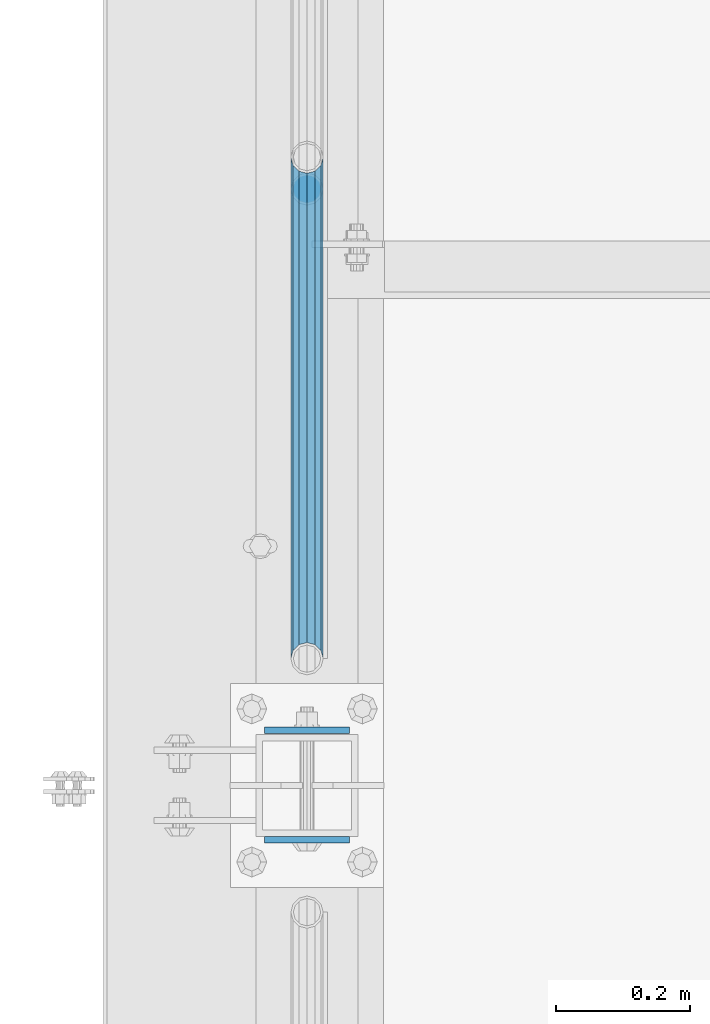
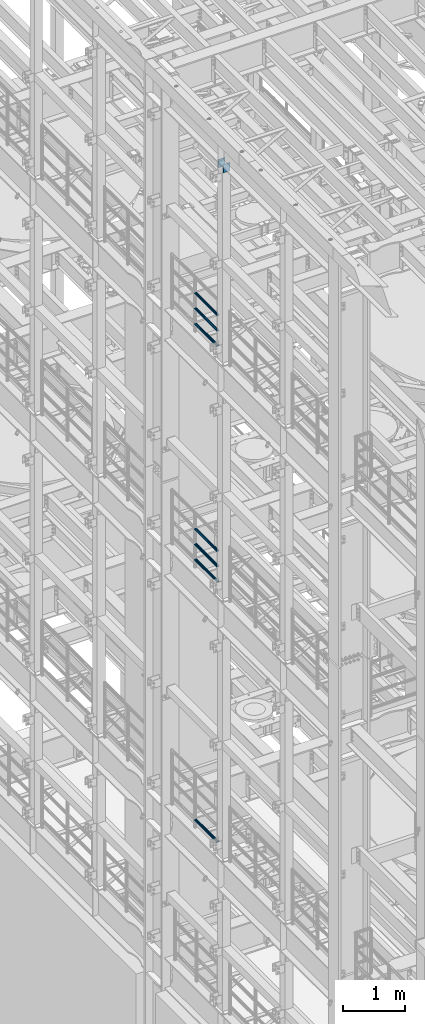
# One storey, part 1230 of 1876: 9 beams, 4 elements without a shape of their own.
"""IFC2X3 building model written with IfcOpenShell, lengths in millimetres."""

from ifc_helpers import new_model, si_unit, frame, origin_with_axes, place, context, subcontext, project, spatial, faceted_brep, material, type_object, element, aggregate, save


model = new_model("IFC2X3")

# Units and contexts
model_context = context("Model", 3, precision=1e-05, world=origin_with_axes())
body_context = subcontext(model_context, "Body", "Model", "MODEL_VIEW")
ifc_project = project(units=[si_unit("LENGTHUNIT", "METRE", prefix="MILLI"), si_unit("AREAUNIT", "SQUARE_METRE"), si_unit("VOLUMEUNIT", "CUBIC_METRE"), si_unit("MASSUNIT", "GRAM", prefix="KILO"), si_unit("TIMEUNIT", "SECOND"), si_unit("PLANEANGLEUNIT", "RADIAN"), si_unit("SOLIDANGLEUNIT", "STERADIAN"), si_unit("THERMODYNAMICTEMPERATUREUNIT", "DEGREE_CELSIUS"), si_unit("LUMINOUSINTENSITYUNIT", "LUMEN")], contexts=[model_context])

# Site, building, storey
site_placement = place(None, origin_with_axes())
site = spatial("IfcSite", under=ifc_project, at=site_placement, CompositionType="ELEMENT")
building_placement = place(site_placement, origin_with_axes())
building = spatial("IfcBuilding", under=site, at=building_placement, Name="Undefined", CompositionType="ELEMENT")
storey_placement = place(building_placement, origin_with_axes())
storey = spatial("IfcBuildingStorey", under=building, at=storey_placement, Name="Undefined", CompositionType="ELEMENT", Elevation=0.0)

# Assembly, beams
assembly_1_placement = place(storey_placement, origin_with_axes())
assembly_1 = element("IfcElementAssembly", 1, at=assembly_1_placement, inside=storey, Name="RAIL", AssemblyPlace="NOTDEFINED", PredefinedType="RIGID_FRAME")
ifc_material_1 = material()
beam_type_1 = type_object("IfcBeamType", Name="PIPE1-1/2SCH40", PredefinedType="NOTDEFINED")
beam_1_placement = place(assembly_1_placement, frame((-1.81898940354586e-12, 430.212499999999, 18145.125), z_axis=(0.0, 0.0, 1.0), x_axis=(0.0, -1.0, 0.0)))
beam_1 = element("IfcBeam", 2, at=beam_1_placement, type_object=beam_type_1, material=ifc_material_1, Name="RAIL", ObjectType="PIPE1-1/2SCH40", context=body_context, shape_type="Brep", body=[
    faceted_brep([(728.085307006683, -12.0649999999996, 20.8971929933177), (728.085307006683, -12.0649999999996, 15.8661214311796), (727.591878568821, -10.2235000000001, 17.7076214311819), (724.852500000002, 0.0, 20.4470000000001), (724.852500000002, 0.0, 24.130000000001), (727.591878568821, 10.2235000000001, 17.7076214311819), (728.085307006683, 12.0649999999996, 15.8661214311796), (728.085307006683, 12.0649999999996, 20.8971929933177), (748.982500000002, 24.1300000000001, 0.0), (736.917500000002, 20.8971929933186, 12.0649999999987), (736.917500000002, 20.8971929933186, -12.0649999999987), (733.727928437864, 17.7076214311801, 10.2235000000001), (736.467307006683, 20.4470000000001, 0.0), (733.727928437864, 17.7076214311801, -10.2235000000001), (728.085307006683, 12.0649999999996, -15.8661214311796), (728.085307006683, 12.0649999999996, -20.8971929933177), (727.591878568821, 10.2235000000001, -17.7076214311819), (724.852500000002, 0.0, -20.4470000000001), (724.852500000002, 0.0, -24.130000000001), (728.085307006683, -12.0649999999996, -15.8661214311796), (728.085307006683, -12.0649999999996, -20.8971929933177), (727.591878568821, -10.2235000000001, -17.7076214311819), (748.982500000002, -24.1300000000001, 0.0), (736.917500000002, -20.8971929933186, -12.0649999999987), (736.917500000002, -20.8971929933186, 12.0649999999987), (733.727928437864, -17.7076214311801, -10.2235000000001), (736.467307006683, -20.4470000000001, 0.0), (733.727928437864, -17.7076214311801, 10.2235000000001), (12.0650000000064, -20.8971929933177, -12.0649999999987), (20.8971929933249, -12.0650000000005, -20.8971929933177), (0.0, 24.1299999999992, 0.0), (12.0650000000064, 20.8971929933177, -12.0649999999987), (12.0650000000064, 20.8971929933177, 12.0649999999987), (20.8971929933249, 12.0650000000005, 20.8971929933177), (24.1300000000064, 0.0, 24.130000000001), (20.8971929933249, 12.0650000000005, -20.8971929933177), (24.1300000000063, 0.0, -24.130000000001), (24.1300000000063, 0.0, -20.4470000000001), (20.8971929933249, -12.0650000000005, -15.8661214311796), (21.3906214311868, -10.2235000000001, -17.7076214311819), (21.3906214311868, 10.2235000000001, -17.7076214311819), (20.8971929933249, 12.0650000000005, -15.8661214311796), (15.2545715621445, 17.7076214311801, -10.2235000000001), (12.5151929933249, 20.4470000000001, 0.0), (15.2545715621445, 17.7076214311801, 10.2235000000001), (20.8971929933249, 12.0650000000005, 15.8661214311796), (21.3906214311868, 10.2235000000001, 17.7076214311819), (24.1300000000064, 0.0, 20.4470000000001), (21.3906214311868, -10.2235000000001, 17.7076214311819), (20.8971929933249, -12.0650000000005, 15.8661214311796), (20.8971929933249, -12.0650000000005, 20.8971929933177), (12.0650000000064, -20.8971929933177, 12.0649999999987), (0.0, -24.1299999999992, 0.0), (15.2545715621445, -17.7076214311801, 10.2235000000001), (12.5151929933249, -20.4470000000001, 0.0), (15.2545715621445, -17.7076214311801, -10.2235000000001)], [[[0, 1, 2, 3, 4]], [[4, 3, 5, 6, 7]], [[8, 9, 10]], [[7, 6, 11, 12, 13, 14, 15, 10, 9]], [[16, 17, 18, 15, 14]], [[19, 20, 18, 17, 21]], [[22, 23, 24]], [[24, 23, 20, 19, 25, 26, 27, 1, 0]], [[28, 29, 20, 23]], [[30, 31, 32]], [[33, 34, 4, 7]], [[32, 33, 7, 9]], [[30, 32, 9, 8]], [[31, 30, 8, 10]], [[35, 31, 10, 15]], [[36, 35, 15, 18]], [[29, 36, 18, 20]], [[37, 36, 29, 38, 39]], [[40, 41, 35, 36, 37]], [[32, 31, 35, 41, 42, 43, 44, 45, 33]], [[33, 45, 46, 47, 34]], [[34, 47, 48, 49, 50]], [[34, 50, 0, 4]], [[50, 51, 24, 0]], [[51, 52, 22, 24]], [[52, 28, 23, 22]], [[51, 28, 52]], [[50, 49, 53, 54, 55, 38, 29, 28, 51]], [[55, 54, 26, 25]], [[21, 39, 38, 55, 25, 19]], [[37, 39, 21, 17]], [[40, 37, 17, 16]], [[42, 41, 40, 16, 14, 13]], [[43, 42, 13, 12]], [[44, 43, 12, 11]], [[5, 46, 45, 44, 11, 6]], [[47, 46, 5, 3]], [[48, 47, 3, 2]], [[53, 49, 48, 2, 1, 27]], [[54, 53, 27, 26]]]),
])
beam_2_placement = place(assembly_1_placement, frame((-1.81898940354586e-12, -318.770000000001, 18449.925), z_axis=(0.0, 0.0, -1.0), x_axis=(0.0, 1.0, 0.0)))
beam_2 = element("IfcBeam", 3, at=beam_2_placement, type_object=beam_type_1, material=ifc_material_1, Name="RAIL", ObjectType="PIPE1-1/2SCH40", context=body_context, shape_type="Brep", body=[
    faceted_brep([(0.0, 24.1299999999992, 0.0), (12.0650000000064, 20.8971929933177, -12.0649999999987), (12.0650000000064, 20.8971929933177, 12.0649999999987), (12.0650000000064, -20.8971929933177, 12.0649999999987), (12.0650000000064, -20.8971929933177, -12.0649999999987), (0.0, -24.1299999999992, 0.0), (20.8971929933249, -12.0650000000005, 20.8971929933177), (20.8971929933249, -12.0650000000005, 15.8661214311796), (15.2545715621445, -17.7076214311801, 10.2235000000001), (12.5151929933249, -20.4470000000001, 0.0), (15.2545715621445, -17.7076214311801, -10.2235000000001), (20.8971929933249, -12.0650000000005, -15.8661214311796), (20.8971929933249, -12.0650000000005, -20.8971929933177), (24.1300000000063, 0.0, -20.4470000000001), (24.1300000000063, 0.0, -24.130000000001), (21.3906214311868, -10.2235000000001, -17.7076214311819), (21.3906214311868, 10.2235000000001, -17.7076214311819), (20.8971929933249, 12.0650000000005, -15.8661214311796), (20.8971929933249, 12.0650000000005, -20.8971929933177), (15.2545715621445, 17.7076214311801, -10.2235000000001), (12.5151929933249, 20.4470000000001, 0.0), (15.2545715621445, 17.7076214311801, 10.2235000000001), (20.8971929933249, 12.0650000000005, 15.8661214311796), (20.8971929933249, 12.0650000000005, 20.8971929933177), (21.3906214311868, 10.2235000000001, 17.7076214311819), (24.1300000000064, 0.0, 20.4470000000001), (24.1300000000064, 0.0, 24.130000000001), (21.3906214311868, -10.2235000000001, 17.7076214311819), (748.982500000002, 24.1300000000001, 0.0), (736.917500000002, 20.8971929933186, -12.0649999999987), (728.085307006683, 12.0649999999996, -20.8971929933177), (748.982500000002, -24.1300000000001, 0.0), (736.917500000002, -20.8971929933186, -12.0649999999987), (736.917500000002, -20.8971929933186, 12.0649999999987), (728.085307006683, -12.0649999999996, 20.8971929933177), (728.085307006683, -12.0649999999996, -20.8971929933177), (724.852500000002, 0.0, -24.130000000001), (727.591878568821, 10.2235000000001, -17.7076214311819), (724.852500000002, 0.0, -20.4470000000001), (728.085307006683, 12.0649999999996, -15.8661214311796), (728.085307006683, -12.0649999999996, -15.8661214311796), (727.591878568821, -10.2235000000001, -17.7076214311819), (733.727928437864, -17.7076214311801, -10.2235000000001), (736.467307006683, -20.4470000000001, 0.0), (733.727928437864, -17.7076214311801, 10.2235000000001), (728.085307006683, -12.0649999999996, 15.8661214311796), (727.591878568821, -10.2235000000001, 17.7076214311819), (724.852500000002, 0.0, 20.4470000000001), (724.852500000002, 0.0, 24.130000000001), (728.085307006683, 12.0649999999996, 20.8971929933177), (736.917500000002, 20.8971929933186, 12.0649999999987), (728.085307006683, 12.0649999999996, 15.8661214311796), (733.727928437864, 17.7076214311801, 10.2235000000001), (736.467307006683, 20.4470000000001, 0.0), (733.727928437864, 17.7076214311801, -10.2235000000001), (727.591878568821, 10.2235000000001, 17.7076214311819)], [[[0, 1, 2]], [[3, 4, 5]], [[6, 7, 8, 9, 10, 11, 12, 4, 3]], [[13, 14, 12, 11, 15]], [[16, 17, 18, 14, 13]], [[2, 1, 18, 17, 19, 20, 21, 22, 23]], [[23, 22, 24, 25, 26]], [[26, 25, 27, 7, 6]], [[1, 0, 28, 29]], [[18, 1, 29, 30]], [[31, 32, 33]], [[6, 3, 33, 34]], [[3, 5, 31, 33]], [[5, 4, 32, 31]], [[4, 12, 35, 32]], [[12, 14, 36, 35]], [[14, 18, 30, 36]], [[37, 38, 36, 30, 39]], [[40, 35, 36, 38, 41]], [[33, 32, 35, 40, 42, 43, 44, 45, 34]], [[34, 45, 46, 47, 48]], [[26, 6, 34, 48]], [[2, 23, 49, 50]], [[23, 26, 48, 49]], [[0, 2, 50, 28]], [[28, 50, 29]], [[49, 51, 52, 53, 54, 39, 30, 29, 50]], [[48, 47, 55, 51, 49]], [[25, 24, 55, 47]], [[55, 24, 22, 21, 52, 51]], [[21, 20, 53, 52]], [[20, 19, 54, 53]], [[19, 17, 16, 37, 39, 54]], [[16, 13, 38, 37]], [[13, 15, 41, 38]], [[41, 15, 11, 10, 42, 40]], [[10, 9, 43, 42]], [[9, 8, 44, 43]], [[8, 7, 27, 46, 45, 44]], [[27, 25, 47, 46]]]),
])
beam_3_placement = place(assembly_1_placement, frame((-1.81898940354586e-12, -318.770000000001, 18754.725), z_axis=(0.0, 0.0, -1.0), x_axis=(0.0, 1.0, 0.0)))
beam_3 = element("IfcBeam", 4, at=beam_3_placement, type_object=beam_type_1, material=ifc_material_1, Name="RAIL", ObjectType="PIPE1-1/2SCH40", context=body_context, shape_type="Brep", body=[
    faceted_brep([(0.0, 24.1299999999992, 0.0), (12.0650000000064, 20.8971929933177, -12.0649999999987), (12.0650000000064, 20.8971929933177, 12.0649999999987), (12.0650000000064, -20.8971929933177, 12.0649999999987), (12.0650000000064, -20.8971929933177, -12.0649999999987), (0.0, -24.1299999999992, 0.0), (20.8971929933249, -12.0650000000005, 20.8971929933177), (20.8971929933249, -12.0650000000005, 15.8661214311796), (15.2545715621445, -17.7076214311801, 10.2235000000001), (12.5151929933249, -20.4470000000001, 0.0), (15.2545715621445, -17.7076214311801, -10.2235000000001), (20.8971929933249, -12.0650000000005, -15.8661214311796), (20.8971929933249, -12.0650000000005, -20.8971929933177), (24.1300000000063, 0.0, -20.4470000000001), (24.1300000000063, 0.0, -24.130000000001), (21.3906214311868, -10.2235000000001, -17.7076214311819), (21.3906214311868, 10.2235000000001, -17.7076214311819), (20.8971929933249, 12.0650000000005, -15.8661214311796), (20.8971929933249, 12.0650000000005, -20.8971929933177), (15.2545715621445, 17.7076214311801, -10.2235000000001), (12.5151929933249, 20.4470000000001, 0.0), (15.2545715621445, 17.7076214311801, 10.2235000000001), (20.8971929933249, 12.0650000000005, 15.8661214311796), (20.8971929933249, 12.0650000000005, 20.8971929933177), (21.3906214311868, 10.2235000000001, 17.7076214311819), (24.1300000000064, 0.0, 20.4470000000001), (24.1300000000064, 0.0, 24.130000000001), (21.3906214311868, -10.2235000000001, 17.7076214311819), (748.982500000002, 24.1300000000001, 0.0), (736.917500000002, 20.8971929933186, -12.0649999999987), (728.085307006683, 12.0649999999996, -20.8971929933177), (748.982500000002, -24.1300000000001, 0.0), (736.917500000002, -20.8971929933186, -12.0649999999987), (736.917500000002, -20.8971929933186, 12.0649999999987), (728.085307006683, -12.0649999999996, 20.8971929933177), (728.085307006683, -12.0649999999996, -20.8971929933177), (724.852500000002, 0.0, -24.130000000001), (727.591878568821, 10.2235000000001, -17.7076214311819), (724.852500000002, 0.0, -20.4470000000001), (728.085307006683, 12.0649999999996, -15.8661214311796), (728.085307006683, -12.0649999999996, -15.8661214311796), (727.591878568821, -10.2235000000001, -17.7076214311819), (733.727928437864, -17.7076214311801, -10.2235000000001), (736.467307006683, -20.4470000000001, 0.0), (733.727928437864, -17.7076214311801, 10.2235000000001), (728.085307006683, -12.0649999999996, 15.8661214311796), (727.591878568821, -10.2235000000001, 17.7076214311819), (724.852500000002, 0.0, 20.4470000000001), (724.852500000002, 0.0, 24.130000000001), (728.085307006683, 12.0649999999996, 20.8971929933177), (736.917500000002, 20.8971929933186, 12.0649999999987), (728.085307006683, 12.0649999999996, 15.8661214311796), (733.727928437864, 17.7076214311801, 10.2235000000001), (736.467307006683, 20.4470000000001, 0.0), (733.727928437864, 17.7076214311801, -10.2235000000001), (727.591878568821, 10.2235000000001, 17.7076214311819)], [[[0, 1, 2]], [[3, 4, 5]], [[6, 7, 8, 9, 10, 11, 12, 4, 3]], [[13, 14, 12, 11, 15]], [[16, 17, 18, 14, 13]], [[2, 1, 18, 17, 19, 20, 21, 22, 23]], [[23, 22, 24, 25, 26]], [[26, 25, 27, 7, 6]], [[1, 0, 28, 29]], [[18, 1, 29, 30]], [[31, 32, 33]], [[6, 3, 33, 34]], [[3, 5, 31, 33]], [[5, 4, 32, 31]], [[4, 12, 35, 32]], [[12, 14, 36, 35]], [[14, 18, 30, 36]], [[37, 38, 36, 30, 39]], [[40, 35, 36, 38, 41]], [[33, 32, 35, 40, 42, 43, 44, 45, 34]], [[34, 45, 46, 47, 48]], [[26, 6, 34, 48]], [[2, 23, 49, 50]], [[23, 26, 48, 49]], [[0, 2, 50, 28]], [[28, 50, 29]], [[49, 51, 52, 53, 54, 39, 30, 29, 50]], [[48, 47, 55, 51, 49]], [[25, 24, 55, 47]], [[55, 24, 22, 21, 52, 51]], [[21, 20, 53, 52]], [[20, 19, 54, 53]], [[19, 17, 16, 37, 39, 54]], [[16, 13, 38, 37]], [[13, 15, 41, 38]], [[41, 15, 11, 10, 42, 40]], [[10, 9, 43, 42]], [[9, 8, 44, 43]], [[8, 7, 27, 46, 45, 44]], [[27, 25, 47, 46]]]),
])
aggregate(assembly_1, [beam_1, beam_2, beam_3])

assembly_2_placement = place(storey_placement, origin_with_axes())
assembly_2 = element("IfcElementAssembly", 5, at=assembly_2_placement, inside=storey, Name="RAIL", AssemblyPlace="NOTDEFINED", PredefinedType="RIGID_FRAME")
beam_4_placement = place(assembly_2_placement, frame((-1.81898940354586e-12, 430.212499999999, 13471.525), z_axis=(0.0, 0.0, 1.0), x_axis=(0.0, -1.0, 0.0)))
beam_4 = element("IfcBeam", 6, at=beam_4_placement, type_object=beam_type_1, material=ifc_material_1, Name="RAIL", ObjectType="PIPE1-1/2SCH40", context=body_context, shape_type="Brep", body=[
    faceted_brep([(728.085307006683, -12.0649999999996, 20.8971929933177), (728.085307006683, -12.0649999999996, 15.8661214311796), (727.591878568821, -10.2235000000001, 17.7076214311819), (724.852500000002, 0.0, 20.4470000000001), (724.852500000002, 0.0, 24.130000000001), (727.591878568821, 10.2235000000001, 17.7076214311819), (728.085307006683, 12.0649999999996, 15.8661214311796), (728.085307006683, 12.0649999999996, 20.8971929933177), (748.982500000002, 24.1300000000001, 0.0), (736.917500000002, 20.8971929933186, 12.0649999999987), (736.917500000002, 20.8971929933186, -12.0649999999987), (733.727928437864, 17.7076214311801, 10.2235000000001), (736.467307006683, 20.4470000000001, 0.0), (733.727928437864, 17.7076214311801, -10.2235000000001), (728.085307006683, 12.0649999999996, -15.8661214311796), (728.085307006683, 12.0649999999996, -20.8971929933177), (727.591878568821, 10.2235000000001, -17.7076214311819), (724.852500000002, 0.0, -20.4470000000001), (724.852500000002, 0.0, -24.130000000001), (728.085307006683, -12.0649999999996, -15.8661214311796), (728.085307006683, -12.0649999999996, -20.8971929933177), (727.591878568821, -10.2235000000001, -17.7076214311819), (748.982500000002, -24.1300000000001, 0.0), (736.917500000002, -20.8971929933186, -12.0649999999987), (736.917500000002, -20.8971929933186, 12.0649999999987), (733.727928437864, -17.7076214311801, -10.2235000000001), (736.467307006683, -20.4470000000001, 0.0), (733.727928437864, -17.7076214311801, 10.2235000000001), (12.0650000000064, -20.8971929933177, -12.0649999999987), (20.8971929933249, -12.0650000000005, -20.8971929933177), (0.0, 24.1299999999992, 0.0), (12.0650000000064, 20.8971929933177, -12.0649999999987), (12.0650000000064, 20.8971929933177, 12.0649999999987), (20.8971929933249, 12.0650000000005, 20.8971929933177), (24.1300000000064, 0.0, 24.130000000001), (20.8971929933249, 12.0650000000005, -20.8971929933177), (24.1300000000063, 0.0, -24.130000000001), (24.1300000000063, 0.0, -20.4470000000001), (20.8971929933249, -12.0650000000005, -15.8661214311796), (21.3906214311868, -10.2235000000001, -17.7076214311819), (21.3906214311868, 10.2235000000001, -17.7076214311819), (20.8971929933249, 12.0650000000005, -15.8661214311796), (15.2545715621445, 17.7076214311801, -10.2235000000001), (12.5151929933249, 20.4470000000001, 0.0), (15.2545715621445, 17.7076214311801, 10.2235000000001), (20.8971929933249, 12.0650000000005, 15.8661214311796), (21.3906214311868, 10.2235000000001, 17.7076214311819), (24.1300000000064, 0.0, 20.4470000000001), (21.3906214311868, -10.2235000000001, 17.7076214311819), (20.8971929933249, -12.0650000000005, 15.8661214311796), (20.8971929933249, -12.0650000000005, 20.8971929933177), (12.0650000000064, -20.8971929933177, 12.0649999999987), (0.0, -24.1299999999992, 0.0), (15.2545715621445, -17.7076214311801, 10.2235000000001), (12.5151929933249, -20.4470000000001, 0.0), (15.2545715621445, -17.7076214311801, -10.2235000000001)], [[[0, 1, 2, 3, 4]], [[4, 3, 5, 6, 7]], [[8, 9, 10]], [[7, 6, 11, 12, 13, 14, 15, 10, 9]], [[16, 17, 18, 15, 14]], [[19, 20, 18, 17, 21]], [[22, 23, 24]], [[24, 23, 20, 19, 25, 26, 27, 1, 0]], [[28, 29, 20, 23]], [[30, 31, 32]], [[33, 34, 4, 7]], [[32, 33, 7, 9]], [[30, 32, 9, 8]], [[31, 30, 8, 10]], [[35, 31, 10, 15]], [[36, 35, 15, 18]], [[29, 36, 18, 20]], [[37, 36, 29, 38, 39]], [[40, 41, 35, 36, 37]], [[32, 31, 35, 41, 42, 43, 44, 45, 33]], [[33, 45, 46, 47, 34]], [[34, 47, 48, 49, 50]], [[34, 50, 0, 4]], [[50, 51, 24, 0]], [[51, 52, 22, 24]], [[52, 28, 23, 22]], [[51, 28, 52]], [[50, 49, 53, 54, 55, 38, 29, 28, 51]], [[55, 54, 26, 25]], [[21, 39, 38, 55, 25, 19]], [[37, 39, 21, 17]], [[40, 37, 17, 16]], [[42, 41, 40, 16, 14, 13]], [[43, 42, 13, 12]], [[44, 43, 12, 11]], [[5, 46, 45, 44, 11, 6]], [[47, 46, 5, 3]], [[48, 47, 3, 2]], [[53, 49, 48, 2, 1, 27]], [[54, 53, 27, 26]]]),
])
beam_5_placement = place(assembly_2_placement, frame((-1.81898940354586e-12, -318.770000000001, 13776.325), z_axis=(0.0, 0.0, -1.0), x_axis=(0.0, 1.0, 0.0)))
beam_5 = element("IfcBeam", 7, at=beam_5_placement, type_object=beam_type_1, material=ifc_material_1, Name="RAIL", ObjectType="PIPE1-1/2SCH40", context=body_context, shape_type="Brep", body=[
    faceted_brep([(0.0, 24.1299999999992, 0.0), (12.0650000000064, 20.8971929933177, -12.0649999999987), (12.0650000000064, 20.8971929933177, 12.0649999999987), (12.0650000000064, -20.8971929933177, 12.0649999999987), (12.0650000000064, -20.8971929933177, -12.0649999999987), (0.0, -24.1299999999992, 0.0), (20.8971929933249, -12.0650000000005, 20.8971929933177), (20.8971929933249, -12.0650000000005, 15.8661214311796), (15.2545715621445, -17.7076214311801, 10.2235000000001), (12.5151929933249, -20.4470000000001, 0.0), (15.2545715621445, -17.7076214311801, -10.2235000000001), (20.8971929933249, -12.0650000000005, -15.8661214311796), (20.8971929933249, -12.0650000000005, -20.8971929933177), (24.1300000000063, 0.0, -20.4470000000001), (24.1300000000063, 0.0, -24.130000000001), (21.3906214311868, -10.2235000000001, -17.7076214311819), (21.3906214311868, 10.2235000000001, -17.7076214311819), (20.8971929933249, 12.0650000000005, -15.8661214311796), (20.8971929933249, 12.0650000000005, -20.8971929933177), (15.2545715621445, 17.7076214311801, -10.2235000000001), (12.5151929933249, 20.4470000000001, 0.0), (15.2545715621445, 17.7076214311801, 10.2235000000001), (20.8971929933249, 12.0650000000005, 15.8661214311796), (20.8971929933249, 12.0650000000005, 20.8971929933177), (21.3906214311868, 10.2235000000001, 17.7076214311819), (24.1300000000064, 0.0, 20.4470000000001), (24.1300000000064, 0.0, 24.130000000001), (21.3906214311868, -10.2235000000001, 17.7076214311819), (748.982500000002, 24.1300000000001, 0.0), (736.917500000002, 20.8971929933186, -12.0649999999987), (728.085307006683, 12.0649999999996, -20.8971929933177), (748.982500000002, -24.1300000000001, 0.0), (736.917500000002, -20.8971929933186, -12.0649999999987), (736.917500000002, -20.8971929933186, 12.0649999999987), (728.085307006683, -12.0649999999996, 20.8971929933177), (728.085307006683, -12.0649999999996, -20.8971929933177), (724.852500000002, 0.0, -24.130000000001), (727.591878568821, 10.2235000000001, -17.7076214311819), (724.852500000002, 0.0, -20.4470000000001), (728.085307006683, 12.0649999999996, -15.8661214311796), (728.085307006683, -12.0649999999996, -15.8661214311796), (727.591878568821, -10.2235000000001, -17.7076214311819), (733.727928437864, -17.7076214311801, -10.2235000000001), (736.467307006683, -20.4470000000001, 0.0), (733.727928437864, -17.7076214311801, 10.2235000000001), (728.085307006683, -12.0649999999996, 15.8661214311796), (727.591878568821, -10.2235000000001, 17.7076214311819), (724.852500000002, 0.0, 20.4470000000001), (724.852500000002, 0.0, 24.130000000001), (728.085307006683, 12.0649999999996, 20.8971929933177), (736.917500000002, 20.8971929933186, 12.0649999999987), (728.085307006683, 12.0649999999996, 15.8661214311796), (733.727928437864, 17.7076214311801, 10.2235000000001), (736.467307006683, 20.4470000000001, 0.0), (733.727928437864, 17.7076214311801, -10.2235000000001), (727.591878568821, 10.2235000000001, 17.7076214311819)], [[[0, 1, 2]], [[3, 4, 5]], [[6, 7, 8, 9, 10, 11, 12, 4, 3]], [[13, 14, 12, 11, 15]], [[16, 17, 18, 14, 13]], [[2, 1, 18, 17, 19, 20, 21, 22, 23]], [[23, 22, 24, 25, 26]], [[26, 25, 27, 7, 6]], [[1, 0, 28, 29]], [[18, 1, 29, 30]], [[31, 32, 33]], [[6, 3, 33, 34]], [[3, 5, 31, 33]], [[5, 4, 32, 31]], [[4, 12, 35, 32]], [[12, 14, 36, 35]], [[14, 18, 30, 36]], [[37, 38, 36, 30, 39]], [[40, 35, 36, 38, 41]], [[33, 32, 35, 40, 42, 43, 44, 45, 34]], [[34, 45, 46, 47, 48]], [[26, 6, 34, 48]], [[2, 23, 49, 50]], [[23, 26, 48, 49]], [[0, 2, 50, 28]], [[28, 50, 29]], [[49, 51, 52, 53, 54, 39, 30, 29, 50]], [[48, 47, 55, 51, 49]], [[25, 24, 55, 47]], [[55, 24, 22, 21, 52, 51]], [[21, 20, 53, 52]], [[20, 19, 54, 53]], [[19, 17, 16, 37, 39, 54]], [[16, 13, 38, 37]], [[13, 15, 41, 38]], [[41, 15, 11, 10, 42, 40]], [[10, 9, 43, 42]], [[9, 8, 44, 43]], [[8, 7, 27, 46, 45, 44]], [[27, 25, 47, 46]]]),
])
beam_6_placement = place(assembly_2_placement, frame((-1.81898940354586e-12, -318.770000000001, 14081.125), z_axis=(0.0, 0.0, -1.0), x_axis=(0.0, 1.0, 0.0)))
beam_6 = element("IfcBeam", 8, at=beam_6_placement, type_object=beam_type_1, material=ifc_material_1, Name="RAIL", ObjectType="PIPE1-1/2SCH40", context=body_context, shape_type="Brep", body=[
    faceted_brep([(0.0, 24.1299999999992, 0.0), (12.0650000000064, 20.8971929933177, -12.0649999999987), (12.0650000000064, 20.8971929933177, 12.0649999999987), (12.0650000000064, -20.8971929933177, 12.0649999999987), (12.0650000000064, -20.8971929933177, -12.0649999999987), (0.0, -24.1299999999992, 0.0), (20.8971929933249, -12.0650000000005, 20.8971929933177), (20.8971929933249, -12.0650000000005, 15.8661214311796), (15.2545715621445, -17.7076214311801, 10.2235000000001), (12.5151929933249, -20.4470000000001, 0.0), (15.2545715621445, -17.7076214311801, -10.2235000000001), (20.8971929933249, -12.0650000000005, -15.8661214311796), (20.8971929933249, -12.0650000000005, -20.8971929933177), (24.1300000000063, 0.0, -20.4470000000001), (24.1300000000063, 0.0, -24.130000000001), (21.3906214311868, -10.2235000000001, -17.7076214311819), (21.3906214311868, 10.2235000000001, -17.7076214311819), (20.8971929933249, 12.0650000000005, -15.8661214311796), (20.8971929933249, 12.0650000000005, -20.8971929933177), (15.2545715621445, 17.7076214311801, -10.2235000000001), (12.5151929933249, 20.4470000000001, 0.0), (15.2545715621445, 17.7076214311801, 10.2235000000001), (20.8971929933249, 12.0650000000005, 15.8661214311796), (20.8971929933249, 12.0650000000005, 20.8971929933177), (21.3906214311868, 10.2235000000001, 17.7076214311819), (24.1300000000064, 0.0, 20.4470000000001), (24.1300000000064, 0.0, 24.130000000001), (21.3906214311868, -10.2235000000001, 17.7076214311819), (748.982500000002, 24.1300000000001, 0.0), (736.917500000002, 20.8971929933186, -12.0649999999987), (728.085307006683, 12.0649999999996, -20.8971929933177), (748.982500000002, -24.1300000000001, 0.0), (736.917500000002, -20.8971929933186, -12.0649999999987), (736.917500000002, -20.8971929933186, 12.0649999999987), (728.085307006683, -12.0649999999996, 20.8971929933177), (728.085307006683, -12.0649999999996, -20.8971929933177), (724.852500000002, 0.0, -24.130000000001), (727.591878568821, 10.2235000000001, -17.7076214311819), (724.852500000002, 0.0, -20.4470000000001), (728.085307006683, 12.0649999999996, -15.8661214311796), (728.085307006683, -12.0649999999996, -15.8661214311796), (727.591878568821, -10.2235000000001, -17.7076214311819), (733.727928437864, -17.7076214311801, -10.2235000000001), (736.467307006683, -20.4470000000001, 0.0), (733.727928437864, -17.7076214311801, 10.2235000000001), (728.085307006683, -12.0649999999996, 15.8661214311796), (727.591878568821, -10.2235000000001, 17.7076214311819), (724.852500000002, 0.0, 20.4470000000001), (724.852500000002, 0.0, 24.130000000001), (728.085307006683, 12.0649999999996, 20.8971929933177), (736.917500000002, 20.8971929933186, 12.0649999999987), (728.085307006683, 12.0649999999996, 15.8661214311796), (733.727928437864, 17.7076214311801, 10.2235000000001), (736.467307006683, 20.4470000000001, 0.0), (733.727928437864, 17.7076214311801, -10.2235000000001), (727.591878568821, 10.2235000000001, 17.7076214311819)], [[[0, 1, 2]], [[3, 4, 5]], [[6, 7, 8, 9, 10, 11, 12, 4, 3]], [[13, 14, 12, 11, 15]], [[16, 17, 18, 14, 13]], [[2, 1, 18, 17, 19, 20, 21, 22, 23]], [[23, 22, 24, 25, 26]], [[26, 25, 27, 7, 6]], [[1, 0, 28, 29]], [[18, 1, 29, 30]], [[31, 32, 33]], [[6, 3, 33, 34]], [[3, 5, 31, 33]], [[5, 4, 32, 31]], [[4, 12, 35, 32]], [[12, 14, 36, 35]], [[14, 18, 30, 36]], [[37, 38, 36, 30, 39]], [[40, 35, 36, 38, 41]], [[33, 32, 35, 40, 42, 43, 44, 45, 34]], [[34, 45, 46, 47, 48]], [[26, 6, 34, 48]], [[2, 23, 49, 50]], [[23, 26, 48, 49]], [[0, 2, 50, 28]], [[28, 50, 29]], [[49, 51, 52, 53, 54, 39, 30, 29, 50]], [[48, 47, 55, 51, 49]], [[25, 24, 55, 47]], [[55, 24, 22, 21, 52, 51]], [[21, 20, 53, 52]], [[20, 19, 54, 53]], [[19, 17, 16, 37, 39, 54]], [[16, 13, 38, 37]], [[13, 15, 41, 38]], [[41, 15, 11, 10, 42, 40]], [[10, 9, 43, 42]], [[9, 8, 44, 43]], [[8, 7, 27, 46, 45, 44]], [[27, 25, 47, 46]]]),
])
aggregate(assembly_2, [beam_4, beam_5, beam_6])

# Assembly, beam
assembly_3_placement = place(storey_placement, origin_with_axes())
assembly_3 = element("IfcElementAssembly", 9, at=assembly_3_placement, inside=storey, Name="RAIL", AssemblyPlace="NOTDEFINED", PredefinedType="RIGID_FRAME")
beam_7_placement = place(assembly_3_placement, frame((-1.81898940354586e-12, 430.212499999999, 8315.325), z_axis=(0.0, 0.0, 1.0), x_axis=(0.0, -1.0, 0.0)))
beam_7 = element("IfcBeam", 10, at=beam_7_placement, type_object=beam_type_1, material=ifc_material_1, Name="RAIL", ObjectType="PIPE1-1/2SCH40", context=body_context, shape_type="Brep", body=[
    faceted_brep([(728.085307006683, -12.0649999999996, 20.8971929933177), (728.085307006683, -12.0649999999996, 15.8661214311796), (727.591878568821, -10.2235000000001, 17.7076214311819), (724.852500000002, 0.0, 20.4470000000001), (724.852500000002, 0.0, 24.130000000001), (727.591878568821, 10.2235000000001, 17.7076214311819), (728.085307006683, 12.0649999999996, 15.8661214311796), (728.085307006683, 12.0649999999996, 20.8971929933177), (748.982500000002, 24.1300000000001, 0.0), (736.917500000002, 20.8971929933186, 12.0649999999987), (736.917500000002, 20.8971929933186, -12.0649999999987), (733.727928437864, 17.7076214311801, 10.2235000000001), (736.467307006683, 20.4470000000001, 0.0), (733.727928437864, 17.7076214311801, -10.2235000000001), (728.085307006683, 12.0649999999996, -15.8661214311796), (728.085307006683, 12.0649999999996, -20.8971929933177), (727.591878568821, 10.2235000000001, -17.7076214311819), (724.852500000002, 0.0, -20.4470000000001), (724.852500000002, 0.0, -24.130000000001), (728.085307006683, -12.0649999999996, -15.8661214311796), (728.085307006683, -12.0649999999996, -20.8971929933177), (727.591878568821, -10.2235000000001, -17.7076214311819), (748.982500000002, -24.1300000000001, 0.0), (736.917500000002, -20.8971929933186, -12.0649999999987), (736.917500000002, -20.8971929933186, 12.0649999999987), (733.727928437864, -17.7076214311801, -10.2235000000001), (736.467307006683, -20.4470000000001, 0.0), (733.727928437864, -17.7076214311801, 10.2235000000001), (12.0650000000064, -20.8971929933177, -12.0649999999987), (20.8971929933249, -12.0650000000005, -20.8971929933177), (0.0, 24.1299999999992, 0.0), (12.0650000000064, 20.8971929933177, -12.0649999999987), (12.0650000000064, 20.8971929933177, 12.0649999999987), (20.8971929933249, 12.0650000000005, 20.8971929933177), (24.1300000000064, 0.0, 24.130000000001), (20.8971929933249, 12.0650000000005, -20.8971929933177), (24.1300000000063, 0.0, -24.130000000001), (24.1300000000063, 0.0, -20.4470000000001), (20.8971929933249, -12.0650000000005, -15.8661214311796), (21.3906214311868, -10.2235000000001, -17.7076214311819), (21.3906214311868, 10.2235000000001, -17.7076214311819), (20.8971929933249, 12.0650000000005, -15.8661214311796), (15.2545715621445, 17.7076214311801, -10.2235000000001), (12.5151929933249, 20.4470000000001, 0.0), (15.2545715621445, 17.7076214311801, 10.2235000000001), (20.8971929933249, 12.0650000000005, 15.8661214311796), (21.3906214311868, 10.2235000000001, 17.7076214311819), (24.1300000000064, 0.0, 20.4470000000001), (21.3906214311868, -10.2235000000001, 17.7076214311819), (20.8971929933249, -12.0650000000005, 15.8661214311796), (20.8971929933249, -12.0650000000005, 20.8971929933177), (12.0650000000064, -20.8971929933177, 12.0649999999987), (0.0, -24.1299999999992, 0.0), (15.2545715621445, -17.7076214311801, 10.2235000000001), (12.5151929933249, -20.4470000000001, 0.0), (15.2545715621445, -17.7076214311801, -10.2235000000001)], [[[0, 1, 2, 3, 4]], [[4, 3, 5, 6, 7]], [[8, 9, 10]], [[7, 6, 11, 12, 13, 14, 15, 10, 9]], [[16, 17, 18, 15, 14]], [[19, 20, 18, 17, 21]], [[22, 23, 24]], [[24, 23, 20, 19, 25, 26, 27, 1, 0]], [[28, 29, 20, 23]], [[30, 31, 32]], [[33, 34, 4, 7]], [[32, 33, 7, 9]], [[30, 32, 9, 8]], [[31, 30, 8, 10]], [[35, 31, 10, 15]], [[36, 35, 15, 18]], [[29, 36, 18, 20]], [[37, 36, 29, 38, 39]], [[40, 41, 35, 36, 37]], [[32, 31, 35, 41, 42, 43, 44, 45, 33]], [[33, 45, 46, 47, 34]], [[34, 47, 48, 49, 50]], [[34, 50, 0, 4]], [[50, 51, 24, 0]], [[51, 52, 22, 24]], [[52, 28, 23, 22]], [[51, 28, 52]], [[50, 49, 53, 54, 55, 38, 29, 28, 51]], [[55, 54, 26, 25]], [[21, 39, 38, 55, 25, 19]], [[37, 39, 21, 17]], [[40, 37, 17, 16]], [[42, 41, 40, 16, 14, 13]], [[43, 42, 13, 12]], [[44, 43, 12, 11]], [[5, 46, 45, 44, 11, 6]], [[47, 46, 5, 3]], [[48, 47, 3, 2]], [[53, 49, 48, 2, 1, 27]], [[54, 53, 27, 26]]]),
])
aggregate(assembly_3, [beam_7])

# Assembly, beams
assembly_4_placement = place(storey_placement, origin_with_axes())
assembly_4 = element("IfcElementAssembly", 11, at=assembly_4_placement, inside=storey, Name="BEAM", AssemblyPlace="NOTDEFINED", PredefinedType="RIGID_FRAME")
ifc_material_2 = material(Name="STEEL/A36")
beam_type_2 = type_object("IfcBeamType", PredefinedType="NOTDEFINED")
beam_8_placement = place(assembly_4_placement, frame((-63.5, -425.450000000001, 21850.35), z_axis=(0.0, 0.0, -1.0), x_axis=(1.0, 0.0, 0.0)))
beam_8 = element("IfcBeam", 12, at=beam_8_placement, type_object=beam_type_2, material=ifc_material_2, Name="PLATE", context=body_context, shape_type="Brep", body=[
    faceted_brep([(0.0, 4.76249999999982, -82.5499999999993), (0.0, 4.76249999999982, 82.5499999999993), (127.0, 4.76249999999982, 82.5499999999993), (127.0, 4.76249999999982, -82.5499999999993), (0.0, -4.76249999999982, 82.5499999999993), (127.0, -4.76249999999982, 82.5499999999993), (0.0, -4.76249999999982, -82.5499999999993), (127.0, -4.76249999999982, -82.5499999999993)], [[[0, 1, 2, 3]], [[1, 4, 5, 2]], [[4, 6, 7, 5]], [[6, 0, 3, 7]], [[5, 7, 3, 2]], [[6, 4, 1, 0]]]),
])
beam_9_placement = place(assembly_4_placement, frame((-63.5, -588.962500000001, 21850.35), z_axis=(0.0, 0.0, -1.0), x_axis=(1.0, 0.0, 0.0)))
beam_9 = element("IfcBeam", 13, at=beam_9_placement, type_object=beam_type_2, material=ifc_material_2, Name="PLATE", context=body_context, shape_type="Brep", body=[
    faceted_brep([(0.0, 4.76249999999982, -82.5499999999993), (0.0, 4.76249999999982, 82.5499999999993), (127.0, 4.76249999999982, 82.5499999999993), (127.0, 4.76249999999982, -82.5499999999993), (0.0, -4.76249999999982, 82.5499999999993), (127.0, -4.76249999999982, 82.5499999999993), (0.0, -4.76249999999982, -82.5499999999993), (127.0, -4.76249999999982, -82.5499999999993)], [[[0, 1, 2, 3]], [[1, 4, 5, 2]], [[4, 6, 7, 5]], [[6, 0, 3, 7]], [[5, 7, 3, 2]], [[6, 4, 1, 0]]]),
])
aggregate(assembly_4, [beam_8, beam_9])

save(model, "model.ifc")
